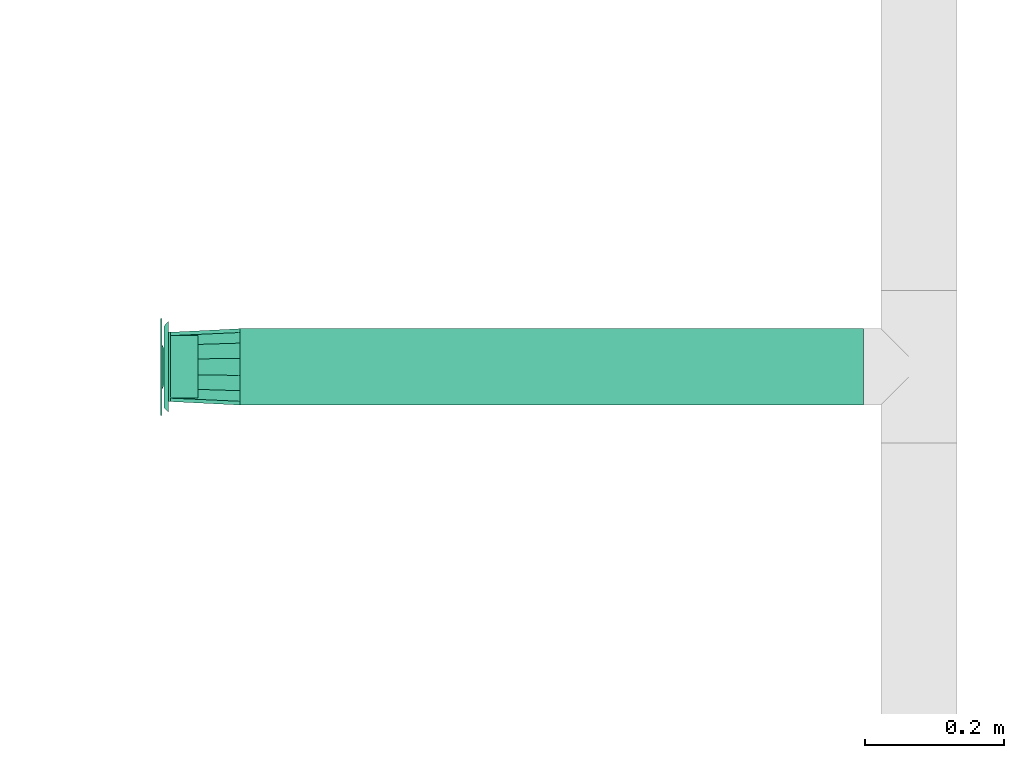
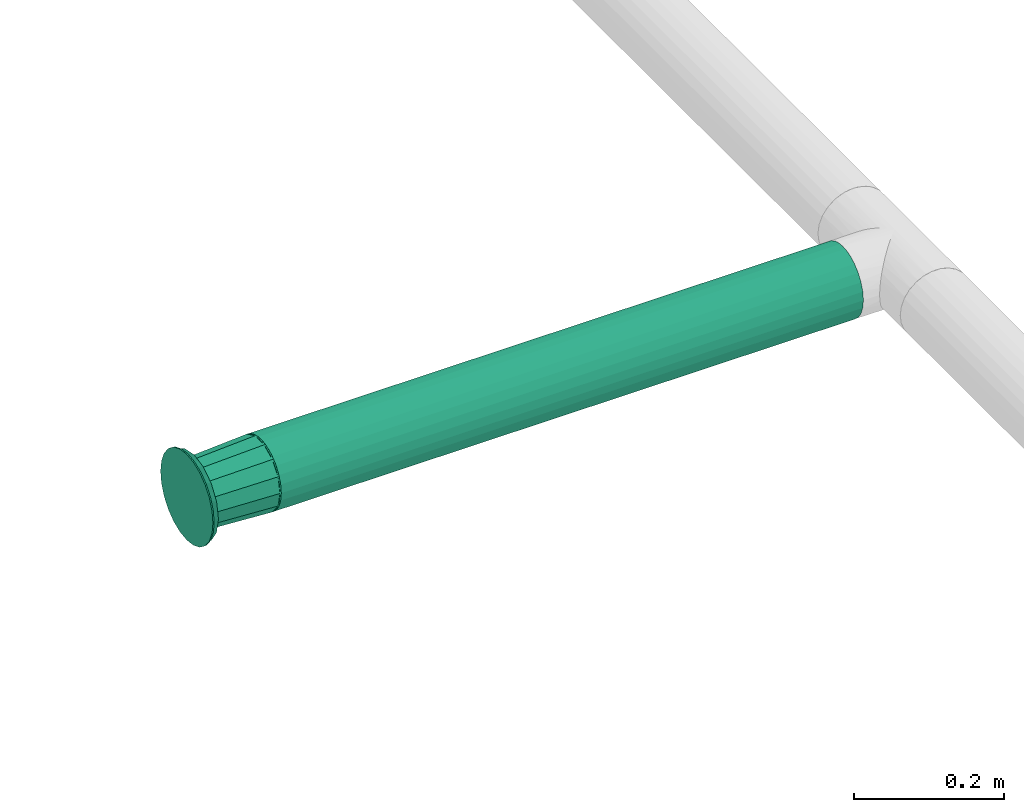
# One storey, part 27 of 123: 1 flow fitting, 1 flow segment, 1 flow terminal.
"""IFC2X3 building model written with IfcOpenShell, lengths in millimetres."""

from ifc_helpers import new_model, entity, si_unit, converted_unit, derived_unit, direction, frame, origin_with_axes, origin_2d_with_axis, place, context, subcontext, project, spatial, hollow_circle, extrude, open_shell, surface_model, source, transform, mapped, material, layer, layer_set, layer_usage, type_object, element, save


model = new_model("IFC2X3")

# Units and contexts
model_context = context("Model", 3, precision=1e-05, world=origin_with_axes(), true_north=direction((0.0, 1.0)))
body_context = subcontext(model_context, "Body", "Model", "MODEL_VIEW")
ifc_project = project(units=[si_unit("AREAUNIT", "SQUARE_METRE"), si_unit("VOLUMEUNIT", "CUBIC_METRE", prefix="DECI"), si_unit("TIMEUNIT", "SECOND"), si_unit("THERMODYNAMICTEMPERATUREUNIT", "DEGREE_CELSIUS"), si_unit("PRESSUREUNIT", "PASCAL"), si_unit("MASSUNIT", "GRAM", prefix="KILO"), si_unit("LENGTHUNIT", "METRE", prefix="MILLI"), si_unit("POWERUNIT", "WATT"), si_unit("ELECTRICCURRENTUNIT", "AMPERE"), si_unit("ELECTRICVOLTAGEUNIT", "VOLT"), derived_unit("VOLUMETRICFLOWRATEUNIT", [(si_unit("VOLUMEUNIT", "CUBIC_METRE", prefix="DECI"), 1), (si_unit("TIMEUNIT", "SECOND"), -1)]), derived_unit("LINEARVELOCITYUNIT", [(si_unit("LENGTHUNIT", "METRE"), 1), (si_unit("TIMEUNIT", "SECOND"), -1)]), derived_unit("MASSDENSITYUNIT", [(si_unit("MASSUNIT", "GRAM", prefix="KILO"), 1), (si_unit("VOLUMEUNIT", "CUBIC_METRE"), -1)]), converted_unit("PLANEANGLEUNIT", "DEGREE", entity("IfcRatioMeasure", 0.01745), si_unit("PLANEANGLEUNIT", "RADIAN"), dimensions=[0, 0, 0, 0, 0, 0, 0])], contexts=[model_context])

# Site, building, storey
site_placement = place(None, origin_with_axes())
site = spatial("IfcSite", under=ifc_project, at=site_placement, CompositionType="ELEMENT")
building_placement = place(site_placement, origin_with_axes())
building = spatial("IfcBuilding", under=site, at=building_placement, Name="mc-building", CompositionType="ELEMENT")
storey_placement = place(building_placement, origin_with_axes())
storey = spatial("IfcBuildingStorey", under=building, at=storey_placement, Name="1. Korrus", CompositionType="ELEMENT", Elevation=0.0)

# Flow segment
ifc_material = material(Name="FZ1")
ifc_layer = layer(ifc_material, 0.0)
ifc_layer_set = layer_set([ifc_layer], Name="FZ1")
ifc_layer_usage = layer_usage(ifc_layer_set, "AXIS1", "POSITIVE", 0.0)
duct_segment_type = type_object("IfcDuctSegmentType", PredefinedType="RIGIDSEGMENT")
shared_shape_1 = source(origin_with_axes(), body_context, "Body", "SweptSolid", [
    extrude(hollow_circle(Radius=55.0, WallThickness=2.0, at=origin_2d_with_axis()), frame((0.0, 0.0, 0.0), z_axis=(1.0, 0.0, 0.0), x_axis=(0.0, 1.0, 0.0)), (0.0, 0.0, 1.0), 898.8),
])
flow_segment_placement = place(storey_placement, frame((8277.82156, 3217.8145, 2465.0), z_axis=(0.0, 0.0, 1.0), x_axis=(-1.0, 0.0, 0.0)))
element("IfcFlowSegment", 1, at=flow_segment_placement, inside=storey, type_object=duct_segment_type, material=ifc_layer_usage, context=body_context, shape_type="MappedRepresentation", body=[
    mapped(shared_shape_1, transform((0.0, 0.0, 0.0), scale=1.0)),
])

# Flow terminal
air_terminal_type = type_object("IfcAirTerminalType", Name="100", PredefinedType="NOTDEFINED")
shared_shape_2 = source(origin_with_axes(), body_context, "Body", "SurfaceModel", [
    surface_model("IfcShellBasedSurfaceModel", [(11.2, -70.0, 0.0), (11.2, -67.61481, -18.11733), (11.2, -67.61481, 18.11733), (6.2, -14.64625, -20.15883), (9.2, -22.36867, -22.36867), (6.2, -21.19625, -15.39997), (9.2, 16.375, -28.36233), (6.2, 8.09625, -24.91768), (6.2, 14.64625, -20.15883), (6.2, -8.09625, -24.91768), (9.2, -16.375, -28.36233), (6.2, 21.19625, -15.39997), (9.2, 22.36867, -22.36867), (9.2, -8.1875, -30.55617), (9.2, 8.1875, -30.55617), (9.2, 28.36233, -16.375), (9.2, -28.36233, -16.375), (6.2, 14.64625, 20.15883), (9.2, 22.36867, 22.36867), (6.2, 21.19625, 15.39997), (9.2, -16.375, 28.36233), (6.2, -8.09625, 24.91768), (6.2, -14.64625, 20.15883), (6.2, 8.09625, 24.91768), (9.2, 16.375, 28.36233), (6.2, -21.19625, 15.39997), (9.2, -22.36867, 22.36867), (9.2, 8.1875, 30.55617), (9.2, -8.1875, 30.55617), (9.2, -28.36233, 16.375), (9.2, 28.36233, 16.375), (6.2, -53.11211, -25.57744), (6.2, -36.75472, -46.08897), (6.2, -13.11761, -57.472), (6.2, 13.11761, -57.472), (6.2, 36.75472, -46.08897), (6.2, 53.11211, -25.57744), (0.0, -12.53288, -63.00706), (6.2, 0.0, -57.472), (0.0, -46.3155, -46.3155), (0.0, -35.69063, -53.4148), (0.0, 0.0, -65.5), (6.2, 44.93342, -35.83321), (0.0, 46.3155, -46.3155), (0.0, 35.69063, -53.4148), (6.2, -44.93342, -35.83321), (0.0, 12.53288, -63.00706), (0.0, 25.06576, -60.51411), (6.2, 56.03105, -12.78872), (0.0, 60.51411, -25.06576), (0.0, 63.00706, -12.53288), (0.0, 53.4148, -35.69063), (0.0, -25.06576, -60.51411), (0.0, -63.00706, -12.53288), (0.0, -60.51411, -25.06576), (6.2, -56.03105, -12.78872), (0.0, -53.4148, -35.69063), (6.2, 13.11761, 57.472), (0.0, 12.53288, 63.00706), (6.2, 0.0, 57.472), (6.2, 36.75472, 46.08897), (0.0, 46.3155, 46.3155), (0.0, 35.69063, 53.4148), (0.0, 0.0, 65.5), (6.2, -44.93342, 35.83321), (6.2, -36.75472, 46.08897), (0.0, -46.3155, 46.3155), (0.0, -35.69063, 53.4148), (6.2, 44.93342, 35.83321), (0.0, -12.53288, 63.00706), (0.0, -25.06576, 60.51411), (6.2, -13.11761, 57.472), (6.2, -56.03105, 12.78872), (0.0, -60.51411, 25.06576), (0.0, -63.00706, 12.53288), (0.0, -53.4148, 35.69063), (0.0, 25.06576, 60.51411), (0.0, 63.00706, 12.53288), (0.0, 60.51411, 25.06576), (6.2, 56.03105, 12.78872), (0.0, 53.4148, 35.69063), (-3.1, 43.30127, 25.0), (-3.1, -48.29629, -12.94095), (-3.1, -43.30127, 25.0), (-3.1, 25.0, -43.30127), (-3.1, 48.29629, -12.94095), (-3.1, 35.35534, -35.35534), (-3.1, -35.35534, -35.35534), (-3.1, -25.0, -43.30127), (-43.1, 43.46666, 11.64686), (-3.1, 38.97115, 22.5), (-3.1, 43.46666, 11.64686), (-3.1, 45.0, 0.0), (-43.1, 45.0, 0.0), (-3.1, 31.81981, 31.81981), (-43.1, 38.97115, 22.5), (-43.1, -38.97115, 22.5), (-3.1, -38.97115, 22.5), (-3.1, -31.81981, 31.81981), (-3.1, -43.46666, 11.64686), (-43.1, -43.46666, 11.64686), (-43.1, -45.0, 0.0), (-3.1, -45.0, 0.0), (-43.1, -43.46666, -11.64686), (-3.1, -38.97115, -22.5), (-3.1, -43.46666, -11.64686), (-3.1, -11.64686, -43.46666), (-3.1, -22.5, -38.97115), (-43.1, -22.5, -38.97115), (-3.1, -31.81981, -31.81981), (-43.1, -38.97115, -22.5), (-43.1, 22.5, -38.97115), (-3.1, 22.5, -38.97115), (-3.1, 11.64686, -43.46666), (-43.1, 38.97115, -22.5), (-3.1, 38.97115, -22.5), (-3.1, 31.81981, -31.81981), (-3.1, 43.46666, -11.64686), (-43.1, 43.46666, -11.64686), (11.2, -49.49747, -49.49747), (11.2, -35.0, -60.62178), (11.2, -18.11733, -67.61481), (11.2, 67.61481, 18.11733), (11.2, -60.62178, -35.0), (11.2, 18.11733, -67.61481), (11.2, 35.0, -60.62178), (11.2, 0.0, -70.0), (11.2, 60.62178, -35.0), (11.2, 67.61481, -18.11733), (11.2, 49.49747, -49.49747), (11.2, -49.49747, 49.49747), (11.2, -60.62178, 35.0), (11.2, -35.0, 60.62178), (11.2, -18.11733, 67.61481), (11.2, 0.0, 70.0), (11.2, 60.62178, 35.0), (11.2, 49.49747, 49.49747), (11.2, 70.0, 0.0), (11.2, 35.0, 60.62178), (11.2, 18.11733, 67.61481), (9.2, -49.49747, 49.49747), (9.2, -35.0, 60.62178), (9.2, -18.11733, 67.61481), (9.2, -67.61481, 18.11733), (9.2, -70.0, 0.0), (9.2, -60.62178, 35.0), (9.2, 67.61481, 18.11733), (9.2, 35.0, 60.62178), (9.2, 18.11733, 67.61481), (9.2, 0.0, 70.0), (9.2, 60.62178, 35.0), (9.2, 49.49747, 49.49747), (9.2, -67.61481, -18.11733), (9.2, -49.49747, -49.49747), (9.2, -60.62178, -35.0), (9.2, -18.11733, -67.61481), (9.2, 70.0, 0.0), (9.2, -35.0, -60.62178), (9.2, 0.0, -70.0), (9.2, 60.62178, -35.0), (9.2, 49.49747, -49.49747), (9.2, 67.61481, -18.11733), (9.2, 35.0, -60.62178), (9.2, 18.11733, -67.61481), (9.2, -32.75, 0.0), (9.2, 0.0, 32.75), (9.2, 32.75, 0.0), (9.2, 0.0, -32.75), (6.2, 26.2, 0.0), (6.2, -26.2, 0.0), (9.2, -31.06579, -6.28555), (6.2, -23.69812, -7.69999), (6.2, 23.69812, -7.69999), (9.2, 31.06579, -6.28555), (6.2, 0.0, -24.91768), (9.2, 31.06579, 6.28555), (6.2, 23.69812, 7.69999), (6.2, -23.69812, 7.69999), (9.2, -31.06579, 6.28555), (6.2, 0.0, 24.91768), (6.2, 53.11211, 25.57744), (6.2, 58.95, 0.0), (6.2, -53.11211, 25.57744), (6.2, -58.95, 0.0), (0.0, 65.5, 0.0), (0.0, -65.5, 0.0), (6.2, -24.93616, -51.78048), (6.2, 24.93616, -51.78048), (6.2, 24.93616, 51.78048), (6.2, -24.93616, 51.78048), (-3.1, 0.0, 50.0), (-3.1, 35.35534, 35.35534), (-3.1, -12.94095, 48.29629), (-3.1, -25.0, 43.30127), (-3.1, -35.35534, 35.35534), (-3.1, 25.0, 43.30127), (-3.1, 12.94095, 48.29629), (-3.1, 48.29629, 12.94095), (-3.1, 50.0, 0.0), (-3.1, -50.0, 0.0), (-3.1, -48.29629, 12.94095), (-3.1, -43.30127, -25.0), (-3.1, -12.94095, -48.29629), (-3.1, 0.0, -50.0), (-3.1, 43.30127, -25.0), (-3.1, 12.94095, -48.29629), (0.0, -12.94095, -48.29629), (0.0, 0.0, -50.0), (0.0, -25.0, -43.30127), (0.0, -35.35534, -35.35534), (0.0, -48.29629, -12.94095), (0.0, 25.0, -43.30127), (0.0, -43.30127, -25.0), (0.0, 43.30127, 25.0), (0.0, 12.94095, -48.29629), (0.0, 43.30127, -25.0), (0.0, 48.29629, -12.94095), (0.0, 35.35534, -35.35534), (0.0, 50.0, 0.0), (0.0, -50.0, 0.0), (0.0, -48.29629, 12.94095), (0.0, -43.30127, 25.0), (0.0, -35.35534, 35.35534), (0.0, -12.94095, 48.29629), (0.0, -25.0, 43.30127), (0.0, 35.35534, 35.35534), (0.0, 0.0, 50.0), (0.0, 48.29629, 12.94095), (0.0, 25.0, 43.30127), (0.0, 12.94095, 48.29629), (-43.1, -22.5, 38.97115), (-43.1, -11.64686, 43.46666), (-43.1, 0.0, 45.0), (-43.1, 11.64686, 43.46666), (-43.1, -31.81981, 31.81981), (-43.1, 31.81981, 31.81981), (-43.1, 22.5, 38.97115), (-43.1, -31.81981, -31.81981), (-43.1, 31.81981, -31.81981), (-43.1, -11.64686, -43.46666), (-43.1, 11.64686, -43.46666), (-43.1, 0.0, -45.0), (-3.1, 0.0, -45.0), (-3.1, 0.0, 45.0), (-3.1, -22.5, 38.97115), (-3.1, -11.64686, 43.46666), (-3.1, 11.64686, 43.46666), (-3.1, 22.5, 38.97115)], [open_shell([[[0, 1, 2]], [[3, 4, 5]], [[6, 7, 8]], [[3, 9, 10]], [[4, 3, 10]], [[11, 12, 8]], [[13, 10, 9]], [[7, 6, 14]], [[6, 8, 12]], [[12, 11, 15]], [[16, 5, 4]], [[17, 18, 19]], [[20, 21, 22]], [[17, 23, 24]], [[18, 17, 24]], [[25, 26, 22]], [[27, 24, 23]], [[21, 20, 28]], [[20, 22, 26]], [[26, 25, 29]], [[30, 19, 18]], [[31, 32, 33]], [[34, 35, 36]], [[33, 37, 38]], [[32, 39, 40]], [[41, 38, 37]], [[42, 35, 43]], [[44, 43, 35]], [[39, 32, 45]], [[46, 47, 34]], [[48, 49, 50]], [[38, 46, 34]], [[42, 43, 51]], [[33, 52, 37]], [[53, 54, 55]], [[46, 38, 41]], [[56, 39, 45]], [[57, 58, 59]], [[60, 61, 62]], [[63, 59, 58]], [[64, 65, 66]], [[67, 66, 65]], [[61, 60, 68]], [[69, 70, 71]], [[72, 73, 74]], [[59, 69, 71]], [[64, 66, 75]], [[57, 76, 58]], [[77, 78, 79]], [[69, 59, 63]], [[80, 61, 68]], [[81, 82, 83]], [[84, 85, 86]], [[87, 82, 88]], [[89, 90, 91]], [[91, 92, 93]], [[94, 90, 95]], [[96, 97, 98]], [[99, 97, 100]], [[101, 102, 99]], [[103, 104, 105]], [[105, 102, 101]], [[106, 107, 108]], [[109, 104, 110]], [[111, 112, 113]], [[114, 115, 116]], [[117, 115, 118]], [[93, 92, 117]], [[119, 120, 121]], [[1, 119, 121]], [[122, 1, 121]], [[123, 119, 1]], [[124, 122, 121]], [[125, 122, 124]], [[121, 126, 124]], [[127, 128, 129]], [[129, 128, 122]], [[129, 122, 125]], [[130, 131, 2]], [[132, 130, 2]], [[122, 133, 2]], [[132, 2, 133]], [[134, 133, 122]], [[135, 136, 122]], [[122, 128, 137]], [[136, 138, 122]], [[139, 122, 138]], [[122, 139, 134]], [[2, 1, 122]], [[140, 141, 142]], [[143, 140, 142]], [[142, 144, 143]], [[145, 140, 143]], [[146, 144, 142]], [[147, 146, 148]], [[149, 148, 146]], [[150, 146, 151]], [[147, 151, 146]], [[146, 142, 149]], [[146, 152, 144]], [[153, 154, 152]], [[155, 153, 152]], [[146, 156, 155]], [[157, 153, 155]], [[158, 155, 156]], [[159, 160, 161]], [[156, 161, 160]], [[160, 162, 156]], [[163, 156, 162]], [[163, 158, 156]], [[152, 146, 155]], [[156, 128, 161]], [[161, 127, 159]], [[162, 160, 125]], [[129, 160, 159]], [[163, 162, 124]], [[128, 127, 161]], [[156, 137, 128]], [[162, 125, 124]], [[125, 160, 129]], [[159, 127, 129]], [[163, 124, 126]], [[126, 158, 163]], [[158, 121, 155]], [[155, 120, 157]], [[154, 153, 123]], [[119, 153, 157]], [[152, 154, 1]], [[120, 119, 157]], [[155, 121, 120]], [[152, 1, 0]], [[1, 154, 123]], [[153, 119, 123]], [[152, 0, 144]], [[126, 121, 158]], [[144, 2, 143]], [[143, 131, 145]], [[141, 140, 132]], [[130, 140, 145]], [[142, 141, 133]], [[2, 131, 143]], [[144, 0, 2]], [[141, 132, 133]], [[132, 140, 130]], [[145, 131, 130]], [[142, 133, 134]], [[134, 149, 142]], [[149, 139, 148]], [[148, 138, 147]], [[150, 151, 135]], [[136, 151, 147]], [[146, 150, 122]], [[138, 136, 147]], [[148, 139, 138]], [[146, 122, 137]], [[122, 150, 135]], [[151, 136, 135]], [[146, 137, 156]], [[134, 139, 149]], [[30, 24, 164]], [[24, 20, 164]], [[165, 20, 24]], [[164, 20, 29]], [[166, 30, 16]], [[16, 6, 166]], [[167, 6, 10]], [[30, 164, 16]], [[10, 6, 16]], [[6, 15, 166]], [[21, 19, 11]], [[23, 19, 21]], [[11, 19, 168]], [[7, 25, 21]], [[7, 5, 169]], [[21, 11, 7]], [[9, 5, 7]], [[169, 25, 7]], [[170, 164, 169]], [[170, 171, 16]], [[11, 172, 15]], [[172, 168, 173]], [[174, 13, 9]], [[166, 173, 168]], [[172, 173, 15]], [[169, 171, 170]], [[5, 16, 171]], [[167, 174, 14]], [[174, 167, 13]], [[14, 174, 7]], [[175, 166, 168]], [[175, 176, 30]], [[25, 177, 29]], [[177, 169, 178]], [[179, 27, 23]], [[164, 178, 169]], [[177, 178, 29]], [[168, 176, 175]], [[19, 30, 176]], [[165, 179, 28]], [[179, 165, 27]], [[28, 179, 21]], [[180, 60, 57]], [[181, 180, 65]], [[65, 57, 71]], [[180, 57, 65]], [[65, 182, 181]], [[182, 36, 181]], [[183, 34, 36]], [[31, 34, 183]], [[31, 33, 34]], [[182, 183, 36]], [[70, 63, 49]], [[70, 73, 66]], [[49, 63, 184]], [[78, 76, 61]], [[76, 78, 184]], [[184, 63, 76]], [[73, 70, 49]], [[39, 54, 185]], [[41, 39, 185]], [[52, 39, 41]], [[43, 185, 49]], [[185, 43, 47]], [[185, 47, 41]], [[73, 49, 185]], [[55, 54, 31]], [[31, 54, 56]], [[52, 186, 40]], [[53, 55, 183]], [[56, 45, 31]], [[185, 53, 183]], [[32, 40, 186]], [[33, 186, 52]], [[44, 35, 187]], [[49, 36, 51]], [[34, 47, 187]], [[42, 51, 36]], [[187, 47, 44]], [[49, 48, 36]], [[48, 50, 181]], [[184, 181, 50]], [[79, 78, 180]], [[180, 78, 80]], [[76, 188, 62]], [[77, 79, 181]], [[80, 68, 180]], [[184, 77, 181]], [[60, 62, 188]], [[57, 188, 76]], [[67, 65, 189]], [[73, 182, 75]], [[71, 70, 189]], [[64, 75, 182]], [[189, 70, 67]], [[73, 72, 182]], [[72, 74, 183]], [[185, 183, 74]], [[190, 191, 192]], [[193, 192, 194]], [[83, 192, 81]], [[194, 192, 83]], [[195, 191, 196]], [[191, 190, 196]], [[197, 198, 81]], [[81, 192, 191]], [[198, 84, 81]], [[199, 200, 83]], [[81, 88, 82]], [[201, 82, 87]], [[88, 81, 202]], [[81, 203, 202]], [[204, 86, 85]], [[205, 203, 84]], [[84, 198, 85]], [[81, 84, 203]], [[199, 83, 82]], [[206, 207, 208]], [[209, 208, 210]], [[210, 208, 211]], [[212, 209, 210]], [[210, 211, 213]], [[214, 211, 207]], [[211, 208, 207]], [[215, 216, 217]], [[211, 217, 216]], [[216, 218, 211]], [[219, 210, 220]], [[221, 210, 213]], [[222, 221, 223]], [[213, 223, 221]], [[224, 222, 223]], [[223, 225, 226]], [[227, 213, 218]], [[218, 213, 211]], [[228, 229, 225]], [[223, 213, 225]], [[226, 225, 229]], [[221, 220, 210]], [[199, 220, 200]], [[200, 221, 83]], [[193, 194, 224]], [[222, 194, 83]], [[192, 193, 223]], [[220, 221, 200]], [[199, 219, 220]], [[193, 224, 223]], [[224, 194, 222]], [[83, 221, 222]], [[192, 223, 226]], [[226, 190, 192]], [[190, 229, 196]], [[196, 228, 195]], [[81, 191, 213]], [[225, 191, 195]], [[197, 81, 227]], [[228, 225, 195]], [[196, 229, 228]], [[197, 227, 218]], [[227, 81, 213]], [[191, 225, 213]], [[197, 218, 198]], [[226, 229, 190]], [[198, 216, 85]], [[85, 215, 204]], [[84, 86, 211]], [[217, 86, 204]], [[205, 84, 214]], [[216, 215, 85]], [[198, 218, 216]], [[84, 211, 214]], [[211, 86, 217]], [[204, 215, 217]], [[205, 214, 207]], [[207, 203, 205]], [[203, 206, 202]], [[202, 208, 88]], [[201, 87, 212]], [[209, 87, 88]], [[82, 201, 210]], [[208, 209, 88]], [[202, 206, 208]], [[82, 210, 219]], [[210, 201, 212]], [[87, 209, 212]], [[82, 219, 199]], [[207, 206, 203]], [[230, 231, 232]], [[230, 232, 233]], [[230, 100, 96]], [[234, 230, 96]], [[100, 230, 233]], [[235, 89, 236]], [[100, 233, 236]], [[95, 89, 235]], [[118, 89, 93]], [[118, 236, 89]], [[118, 100, 236]], [[110, 103, 101]], [[237, 110, 101]], [[238, 108, 101]], [[237, 101, 108]], [[239, 108, 238]], [[114, 238, 118]], [[238, 101, 118]], [[240, 241, 111]], [[238, 111, 241]], [[238, 241, 239]], [[100, 118, 101]], [[106, 242, 107]], [[107, 112, 109]], [[102, 105, 104]], [[112, 104, 109]], [[92, 104, 117]], [[113, 112, 242]], [[112, 107, 242]], [[115, 117, 116]], [[112, 116, 117]], [[112, 117, 104]], [[92, 102, 104]], [[97, 99, 243]], [[98, 97, 244]], [[243, 245, 244]], [[97, 243, 244]], [[246, 243, 99]], [[90, 94, 91]], [[92, 91, 247]], [[94, 247, 91]], [[247, 99, 92]], [[247, 246, 99]], [[102, 92, 99]], [[101, 99, 100]], [[100, 97, 96]], [[230, 234, 244]], [[98, 234, 96]], [[231, 230, 245]], [[245, 230, 244]], [[244, 234, 98]], [[245, 243, 231]], [[243, 232, 231]], [[236, 233, 246]], [[236, 247, 235]], [[89, 95, 90]], [[94, 95, 235]], [[93, 89, 91]], [[232, 246, 233]], [[246, 247, 236]], [[243, 246, 232]], [[247, 94, 235]], [[93, 117, 118]], [[118, 115, 114]], [[111, 238, 112]], [[116, 238, 114]], [[240, 111, 113]], [[112, 238, 116]], [[240, 113, 242]], [[242, 241, 240]], [[108, 239, 106]], [[108, 107, 237]], [[103, 110, 104]], [[109, 110, 237]], [[101, 103, 105]], [[241, 106, 239]], [[242, 106, 241]], [[107, 109, 237]]])]),
])
flow_terminal_placement = place(storey_placement, frame((7275.97051, 3217.8145, 2465.0), z_axis=(0.0, 0.0, 1.0), x_axis=(-1.0, 0.0, 0.0)))
element("IfcFlowTerminal", 2, at=flow_terminal_placement, inside=storey, type_object=air_terminal_type, Name="100", context=body_context, shape_type="MappedRepresentation", body=[
    mapped(shared_shape_2, transform((0.0, 0.0, 0.0), scale=1.0)),
])

# Flow fitting
duct_fitting_type = type_object("IfcDuctFittingType", PredefinedType="TRANSITION")
shared_shape_3 = source(origin_with_axes(), body_context, "Body", "SurfaceModel", [
    surface_model("IfcShellBasedSurfaceModel", [(100.0, -55.0, 0.0), (100.0, -12.23865, 53.62104), (100.0, -34.29194, 43.00073), (100.0, 49.55329, 23.86361), (100.0, 34.29194, 43.00073), (100.0, 49.55329, -23.86361), (0.0, -45.04844, -21.69419), (0.0, -50.0, 0.0), (0.0, -45.04844, 21.69419), (0.0, 31.17449, 39.09157), (0.0, 45.04844, 21.69419), (0.0, 50.0, 0.0), (98.0, 47.63139, 27.5), (98.0, 0.0, 55.0), (98.0, 38.89087, 38.89087), (98.0, -38.89087, 38.89087), (98.0, -47.63139, 27.5), (100.0, 12.23865, 53.62104), (100.0, -49.55329, 23.86361), (100.0, 55.0, 0.0), (100.0, 12.23865, -53.62104), (100.0, 34.29194, -43.00073), (100.0, -49.55329, -23.86361), (100.0, -34.29194, -43.00073), (100.0, -12.23865, -53.62104), (0.0, -31.17449, 39.09157), (0.0, -11.12605, 48.7464), (0.0, 11.12605, 48.7464), (0.0, -31.17449, -39.09157), (0.0, 11.12605, -48.7464), (0.0, -11.12605, -48.7464), (0.0, 45.04844, -21.69419), (0.0, 31.17449, -39.09157), (0.0, 47.52422, -10.84709), (0.0, 38.11147, -30.39288), (100.0, 41.92261, -33.43217), (100.0, -41.92261, -33.43217), (0.0, -38.11147, -30.39288), (100.0, 23.2653, -48.31088), (0.0, 21.15027, -43.91899), (100.0, 52.32388, -11.72483), (0.0, 0.0, -48.7464), (100.0, 0.0, -53.62104), (0.0, -21.15027, -43.91899), (100.0, -23.2653, -48.31088), (0.0, -47.52422, -10.84709), (100.0, -52.32388, -11.72483), (0.0, -47.52422, 10.84709), (0.0, -38.11147, 30.39288), (100.0, -41.92261, 33.43217), (100.0, 41.92261, 33.43217), (0.0, 38.11147, 30.39288), (100.0, -23.2653, 48.31088), (0.0, -21.15027, 43.91899), (100.0, -52.32388, 11.72483), (0.0, 0.0, 48.7464), (100.0, 0.0, 53.62104), (0.0, 21.15027, 43.91899), (100.0, 23.2653, 48.31088), (0.0, 47.52422, 10.84709), (100.0, 52.32388, 11.72483), (100.0, -14.23505, -53.12592), (100.0, 0.0, -55.0), (100.0, -27.5, -47.63139), (100.0, 27.5, -47.63139), (100.0, -38.89087, -38.89087), (100.0, -53.12592, -14.23505), (100.0, -47.63139, -27.5), (100.0, -47.63139, 27.5), (100.0, 14.23505, -53.12592), (100.0, 38.89087, -38.89087), (100.0, 47.63139, -27.5), (100.0, 47.63139, 27.5), (100.0, 53.12592, -14.23505), (100.0, -53.12592, 14.23505), (100.0, -38.89087, 38.89087), (100.0, -27.5, 47.63139), (100.0, 0.0, 55.0), (100.0, -14.23505, 53.12592), (100.0, 53.12592, 14.23505), (100.0, 38.89087, 38.89087), (100.0, 27.5, 47.63139), (100.0, 14.23505, 53.12592), (98.0, -27.5, 47.63139), (98.0, -14.23505, 53.12592), (98.0, -53.12592, -14.23505), (98.0, 14.23505, 53.12592), (98.0, 27.5, 47.63139), (98.0, 53.12592, 14.23505), (98.0, 55.0, 0.0), (98.0, -47.63139, -27.5), (98.0, -53.12592, 14.23505), (98.0, 27.5, -47.63139), (98.0, -27.5, -47.63139), (98.0, -38.89087, -38.89087), (98.0, 0.0, -55.0), (98.0, -14.23505, -53.12592), (98.0, 38.89087, -38.89087), (98.0, 47.63139, -27.5), (98.0, 53.12592, -14.23505), (98.0, 14.23505, -53.12592), (98.0, -55.0, 0.0), (0.0, 0.0, 50.0), (0.0, 35.35534, 35.35534), (0.0, -12.94095, 48.29629), (0.0, -25.0, 43.30127), (0.0, -35.35534, 35.35534), (0.0, -48.29629, 12.94095), (0.0, -43.30127, 25.0), (0.0, 25.0, 43.30127), (0.0, 12.94095, 48.29629), (0.0, 43.30127, 25.0), (0.0, 48.29629, 12.94095), (0.0, 25.0, -43.30127), (0.0, 48.29629, -12.94095), (0.0, -48.29629, -12.94095), (0.0, -43.30127, -25.0), (0.0, -12.94095, -48.29629), (0.0, -25.0, -43.30127), (0.0, -35.35534, -35.35534), (0.0, 43.30127, -25.0), (0.0, 35.35534, -35.35534), (0.0, 12.94095, -48.29629), (0.0, 0.0, -50.0), (2.0, -35.35534, -35.35534), (2.0, -25.0, -43.30127), (2.0, -12.94095, -48.29629), (2.0, -43.30127, -25.0), (2.0, 0.0, -50.0), (2.0, -48.29629, -12.94095), (2.0, -50.0, 0.0), (2.0, 12.94095, -48.29629), (2.0, 25.0, -43.30127), (2.0, 43.30127, -25.0), (2.0, 48.29629, -12.94095), (2.0, 35.35534, -35.35534), (2.0, -48.29629, 12.94095), (2.0, -35.35534, 35.35534), (2.0, -43.30127, 25.0), (2.0, 35.35534, 35.35534), (2.0, -12.94095, 48.29629), (2.0, -25.0, 43.30127), (2.0, 0.0, 50.0), (2.0, 43.30127, 25.0), (2.0, 48.29629, 12.94095), (2.0, 50.0, 0.0), (2.0, 25.0, 43.30127), (2.0, 12.94095, 48.29629)], [open_shell([[[0, 1, 2]], [[3, 4, 5]], [[6, 7, 8]], [[9, 10, 11]], [[12, 13, 14]], [[15, 13, 16]], [[0, 4, 17]], [[2, 18, 0]], [[1, 0, 17]], [[3, 5, 19]], [[20, 21, 5]], [[22, 20, 5]], [[22, 5, 0]], [[22, 23, 24]], [[22, 24, 20]], [[4, 0, 5]], [[8, 25, 6]], [[6, 25, 26]], [[6, 26, 27]], [[11, 27, 9]], [[28, 6, 29]], [[30, 28, 29]], [[31, 6, 11]], [[31, 32, 29]], [[31, 29, 6]], [[27, 11, 6]], [[31, 33, 5]], [[34, 35, 32]], [[36, 22, 6]], [[36, 37, 23]], [[38, 29, 39]], [[33, 40, 5]], [[33, 11, 40]], [[19, 40, 11]], [[32, 21, 39]], [[32, 35, 21]], [[34, 31, 35]], [[30, 41, 42]], [[28, 43, 44]], [[42, 41, 20]], [[7, 45, 46]], [[38, 39, 21]], [[46, 0, 7]], [[6, 37, 36]], [[38, 20, 29]], [[43, 30, 24]], [[42, 24, 30]], [[28, 23, 37]], [[6, 22, 45]], [[35, 31, 5]], [[44, 43, 24]], [[20, 41, 29]], [[46, 45, 22]], [[44, 23, 28]], [[8, 47, 18]], [[48, 49, 25]], [[50, 3, 10]], [[50, 51, 4]], [[52, 26, 53]], [[47, 54, 18]], [[47, 7, 54]], [[0, 54, 7]], [[25, 2, 53]], [[25, 49, 2]], [[48, 8, 49]], [[27, 55, 56]], [[9, 57, 58]], [[56, 55, 1]], [[11, 59, 60]], [[52, 53, 2]], [[60, 19, 11]], [[10, 51, 50]], [[52, 1, 26]], [[57, 27, 17]], [[56, 17, 27]], [[9, 4, 51]], [[10, 3, 59]], [[49, 8, 18]], [[58, 57, 17]], [[1, 55, 26]], [[60, 59, 3]], [[58, 4, 9]], [[61, 62, 63]], [[63, 64, 65]], [[66, 67, 68]], [[65, 64, 67]], [[67, 64, 68]], [[69, 64, 62]], [[64, 63, 62]], [[70, 71, 64]], [[72, 64, 71]], [[71, 73, 19]], [[74, 0, 66]], [[72, 68, 64]], [[75, 68, 76]], [[77, 78, 76]], [[72, 76, 68]], [[76, 72, 77]], [[79, 72, 19]], [[19, 72, 71]], [[80, 81, 77]], [[77, 72, 80]], [[82, 77, 81]], [[74, 66, 68]], [[83, 84, 13]], [[15, 83, 13]], [[12, 16, 13]], [[16, 12, 85]], [[86, 87, 13]], [[87, 14, 13]], [[88, 89, 12]], [[89, 90, 12]], [[91, 16, 85]], [[90, 85, 12]], [[89, 92, 90]], [[93, 94, 95]], [[95, 94, 90]], [[96, 93, 95]], [[97, 92, 98]], [[98, 89, 99]], [[100, 95, 92]], [[92, 89, 98]], [[90, 92, 95]], [[101, 91, 85]], [[89, 73, 99]], [[99, 71, 98]], [[92, 97, 64]], [[70, 97, 98]], [[100, 92, 69]], [[73, 71, 99]], [[89, 19, 73]], [[92, 64, 69]], [[64, 97, 70]], [[98, 71, 70]], [[100, 69, 62]], [[62, 95, 100]], [[95, 61, 96]], [[96, 63, 93]], [[90, 94, 67]], [[65, 94, 93]], [[85, 90, 66]], [[63, 65, 93]], [[96, 61, 63]], [[85, 66, 0]], [[66, 90, 67]], [[94, 65, 67]], [[85, 0, 101]], [[62, 61, 95]], [[101, 74, 91]], [[91, 68, 16]], [[83, 15, 76]], [[75, 15, 16]], [[84, 83, 78]], [[74, 68, 91]], [[101, 0, 74]], [[83, 76, 78]], [[76, 15, 75]], [[16, 68, 75]], [[84, 78, 77]], [[77, 13, 84]], [[13, 82, 86]], [[86, 81, 87]], [[12, 14, 72]], [[80, 14, 87]], [[88, 12, 79]], [[81, 80, 87]], [[86, 82, 81]], [[88, 79, 19]], [[79, 12, 72]], [[14, 80, 72]], [[88, 19, 89]], [[77, 82, 13]], [[102, 103, 104]], [[105, 104, 106]], [[107, 108, 106]], [[103, 106, 104]], [[106, 103, 107]], [[109, 103, 110]], [[103, 102, 110]], [[111, 112, 103]], [[113, 103, 112]], [[112, 11, 114]], [[107, 103, 113]], [[113, 115, 107]], [[116, 115, 117]], [[117, 118, 119]], [[116, 117, 119]], [[117, 115, 113]], [[120, 121, 114]], [[113, 114, 121]], [[113, 122, 117]], [[113, 112, 114]], [[117, 122, 123]], [[7, 107, 115]], [[124, 125, 126]], [[127, 124, 126]], [[128, 129, 126]], [[127, 126, 129]], [[130, 129, 128]], [[131, 132, 128]], [[132, 130, 128]], [[133, 134, 135]], [[132, 135, 134]], [[132, 134, 130]], [[134, 136, 130]], [[137, 138, 136]], [[137, 136, 139]], [[140, 137, 139]], [[141, 137, 140]], [[142, 140, 139]], [[143, 139, 144]], [[144, 134, 145]], [[146, 147, 139]], [[139, 136, 144]], [[139, 147, 142]], [[136, 134, 144]], [[11, 134, 114]], [[114, 133, 120]], [[113, 121, 132]], [[135, 121, 120]], [[122, 113, 131]], [[134, 133, 114]], [[11, 145, 134]], [[113, 132, 131]], [[132, 121, 135]], [[120, 133, 135]], [[122, 131, 128]], [[128, 123, 122]], [[123, 126, 117]], [[117, 125, 118]], [[116, 119, 127]], [[124, 119, 118]], [[115, 116, 129]], [[125, 124, 118]], [[117, 126, 125]], [[115, 129, 130]], [[129, 116, 127]], [[119, 124, 127]], [[115, 130, 7]], [[128, 126, 123]], [[7, 136, 107]], [[107, 138, 108]], [[105, 106, 141]], [[137, 106, 108]], [[104, 105, 140]], [[136, 138, 107]], [[7, 130, 136]], [[105, 141, 140]], [[141, 106, 137]], [[108, 138, 137]], [[104, 140, 142]], [[142, 102, 104]], [[102, 147, 110]], [[110, 146, 109]], [[111, 103, 143]], [[139, 103, 109]], [[112, 111, 144]], [[146, 139, 109]], [[110, 147, 146]], [[112, 144, 145]], [[144, 111, 143]], [[103, 139, 143]], [[112, 145, 11]], [[142, 147, 102]]])]),
])
flow_fitting_placement = place(storey_placement, frame((7279.07051, 3217.8145, 2465.0), z_axis=(0.0, 0.0, 1.0), x_axis=(1.0, 0.0, 0.0)))
element("IfcFlowFitting", 3, at=flow_fitting_placement, inside=storey, type_object=duct_fitting_type, context=body_context, shape_type="MappedRepresentation", body=[
    mapped(shared_shape_3, transform((0.0, 0.0, 0.0), scale=1.0)),
])

save(model, "model.ifc")
